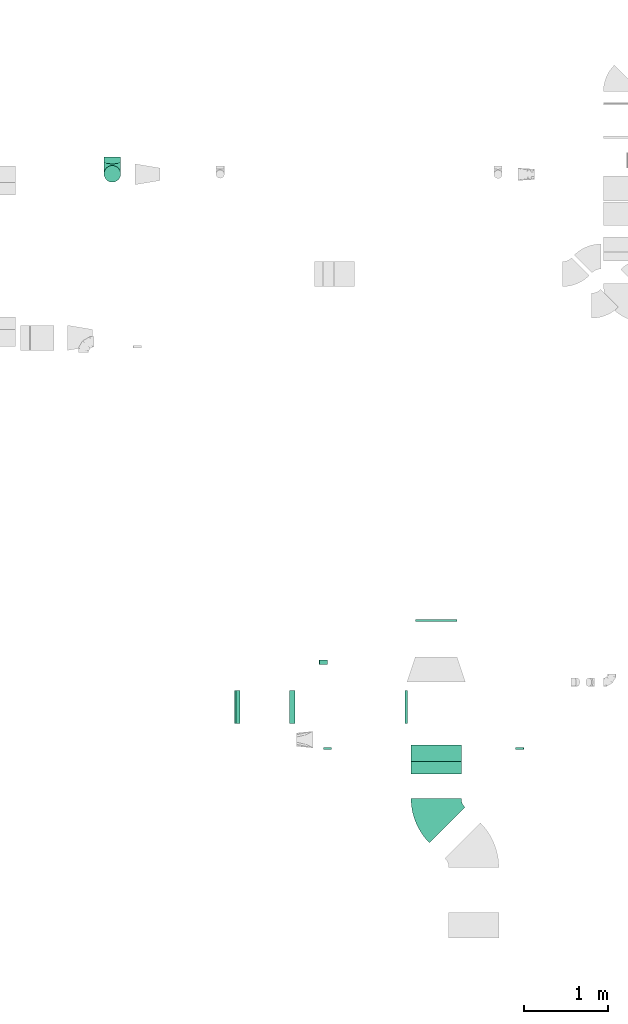
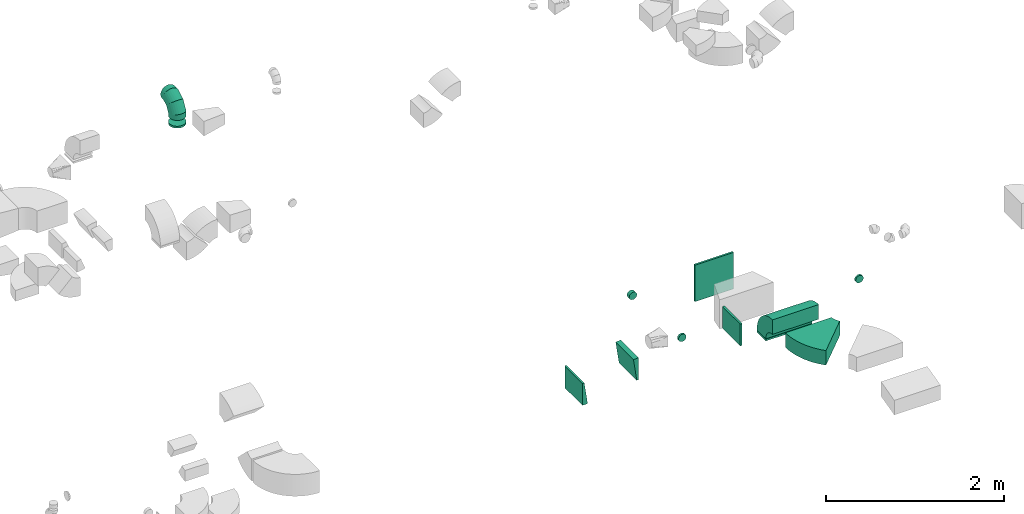
# One storey, part 21 of 44: 12 flow fittings.
"""IFC2X3 building model written with IfcOpenShell, lengths in millimetres."""

import ifcopenshell
import ifcopenshell.guid

model = None  # the IFC model being written
_history = None  # IfcOwnerHistory: only IFC2X3 demands one
_inside = {}  # id of a spatial element -> (the spatial element, [elements in it])
_under = {}  # id of a project, library or spatial element -> (it, [spatial elements below it])
_declared = {}  # id of a project -> (the project, [libraries it declares])
_typed = {}  # id of a type object -> (the type object, [elements of that type])
_made_of = {}  # id of a material, layer set ... -> (it, [elements and type objects made of it])


def new_model(schema):
    """Start an empty IFC model of exactly this schema.

    Asked for "IFC4X3", IfcOpenShell would pick the latest addendum, in which some entities
    have other attributes; the version numbers below select the first issue.
    IFC2X3 requires an IfcOwnerHistory on every rooted entity: one is made here for all.
    """
    global model, _history
    if schema == "IFC4X3":
        model = ifcopenshell.file(schema_version=(4, 3, 0, 0))
    else:
        model = ifcopenshell.file(schema=schema)
    _inside.clear()
    _under.clear()
    _declared.clear()
    _typed.clear()
    _made_of.clear()
    _history = None
    if model.schema == "IFC2X3":
        org = make("IfcOrganization", Name="unknown")
        user = make(
            "IfcPersonAndOrganization",
            ThePerson=make("IfcPerson", FamilyName="unknown"),
            TheOrganization=org,
        )
        app = make(
            "IfcApplication",
            ApplicationDeveloper=org,
            Version="unknown",
            ApplicationFullName="unknown",
            ApplicationIdentifier="unknown",
        )
        _history = make(
            "IfcOwnerHistory",
            OwningUser=user,
            OwningApplication=app,
            ChangeAction="ADDED",
            CreationDate=0,
        )
    return model


def make(cls, **values):
    """One entity of the class cls with the attributes given. An attribute that is None is left unset."""
    return model.create_entity(
        cls, **{name: value for name, value in values.items() if value is not None}
    )


def entity(cls, *values):
    """Any entity or typed value of the class cls, its attributes in the order of the schema. None: left unset."""
    e = model.create_entity(cls)
    for i, value in enumerate(values):
        if value is not None:
            e[i] = value
    return e


def rooted(cls, **values):
    """An entity with a GlobalId (a new one), such as an element, a storey or a relation."""
    return make(cls, GlobalId=ifcopenshell.guid.new(), OwnerHistory=_history, **values)


def si_unit(unit_type, name, prefix=None):
    """IfcSIUnit, for example si_unit("LENGTHUNIT", "METRE", prefix="MILLI")."""
    return make("IfcSIUnit", UnitType=unit_type, Prefix=prefix, Name=name)


def converted_unit(unit_type, name, factor, base, dimensions=None, offset=None):
    """IfcConversionBasedUnit, such as the inch: factor (a typed value) times the base unit."""
    return make(
        "IfcConversionBasedUnit"
        if offset is None
        else "IfcConversionBasedUnitWithOffset",
        ConversionOffset=offset,
        Dimensions=None
        if dimensions is None
        else entity("IfcDimensionalExponents", *dimensions),
        UnitType=unit_type,
        Name=name,
        ConversionFactor=make(
            "IfcMeasureWithUnit", ValueComponent=factor, UnitComponent=base
        ),
    )


def derived_unit(unit_type, elements):
    """IfcDerivedUnit: a product of units, each with its exponent."""
    return make(
        "IfcDerivedUnit",
        Elements=[
            make("IfcDerivedUnitElement", Unit=unit, Exponent=power)
            for unit, power in elements
        ],
        UnitType=unit_type,
    )


def assignment(units):
    """IfcUnitAssignment: the units of a project."""
    return None if units is None else make("IfcUnitAssignment", Units=units)


def point(xyz):
    """IfcCartesianPoint."""
    return None if xyz is None else make("IfcCartesianPoint", Coordinates=xyz)


def direction(xyz):
    """IfcDirection."""
    return None if xyz is None else make("IfcDirection", DirectionRatios=xyz)


def frame(location, z_axis=None, x_axis=None):
    """IfcAxis2Placement3D, a coordinate frame: its origin and axes. An axis left out is left unset."""
    return make(
        "IfcAxis2Placement3D",
        Location=point(location),
        Axis=direction(z_axis),
        RefDirection=direction(x_axis),
    )


def frame_2d(location, x_axis=None):
    """IfcAxis2Placement2D, a coordinate frame in the plane: its origin and x axis."""
    return make(
        "IfcAxis2Placement2D", Location=point(location), RefDirection=direction(x_axis)
    )


def origin():
    """The frame at (0, 0, 0) with its axes left unset."""
    return frame((0.0, 0.0, 0.0))


def origin_2d_with_axis():
    """The frame at (0, 0) in the plane with the x axis (1, 0) written out."""
    return frame_2d((0.0, 0.0), x_axis=(1.0, 0.0))


def place(relative_to, where):
    """IfcLocalPlacement: puts the frame where relative to a parent placement (None: the world)."""
    return make(
        "IfcLocalPlacement", PlacementRelTo=relative_to, RelativePlacement=where
    )


def context(
    kind, dimensions, precision=None, world=None, true_north=None, identifier=None
):
    """IfcGeometricRepresentationContext, for example the 3D "Model" context."""
    return make(
        "IfcGeometricRepresentationContext",
        ContextIdentifier=identifier,
        ContextType=kind,
        CoordinateSpaceDimension=dimensions,
        Precision=precision,
        WorldCoordinateSystem=world,
        TrueNorth=true_north,
    )


def subcontext(parent, identifier, kind, view, scale=None):
    """IfcGeometricRepresentationSubContext, for example "Body" below "Model"."""
    return make(
        "IfcGeometricRepresentationSubContext",
        ContextIdentifier=identifier,
        ContextType=kind,
        ParentContext=parent,
        TargetScale=scale,
        TargetView=view,
    )


def project(units=None, contexts=None):
    """IfcProject with its units and contexts."""
    return rooted(
        "IfcProject",
        Name="project",
        RepresentationContexts=contexts,
        UnitsInContext=assignment(units),
    )


def spatial(cls, under=None, at=None, **own):
    """A site, building, storey or space (cls), placed at a placement, below another one or the project."""
    s = rooted(cls, ObjectPlacement=at, **own)
    if under is not None:
        _under.setdefault(under.id(), (under, []))[1].append(s)
    return s


def polyline(points):
    """IfcPolyline through the points."""
    return make("IfcPolyline", Points=[point(p) for p in points])


def circle_curve(where, radius):
    """IfcCircle in the frame where."""
    return make("IfcCircle", Position=where, Radius=radius)


def parameter(value):
    """IfcParameterValue: where a trimmed curve begins or ends, as a parameter of its basis curve."""
    return model.create_entity("IfcParameterValue", value)


def trimmed(basis, trim1, trim2, sense, master):
    """IfcTrimmedCurve: the piece of a basis curve between two trims."""
    return make(
        "IfcTrimmedCurve",
        BasisCurve=basis,
        Trim1=trim1,
        Trim2=trim2,
        SenseAgreement=sense,
        MasterRepresentation=master,
    )


def segment(curve, same_sense, transition):
    """IfcCompositeCurveSegment."""
    return make(
        "IfcCompositeCurveSegment",
        Transition=transition,
        SameSense=same_sense,
        ParentCurve=curve,
    )


def composite_curve(segments, self_intersect=None):
    """IfcCompositeCurve: segments joined end to end."""
    return make("IfcCompositeCurve", Segments=segments, SelfIntersect=self_intersect)


def profile(cls, at=None, kind="AREA", **sizes):
    """A parametric profile (cls). Its sizes go by their IFC names, for example OverallWidth=200.0."""
    return make(cls, ProfileType=kind, Position=at, **sizes)


def rectangle(**sizes):
    """IfcRectangleProfileDef."""
    return profile("IfcRectangleProfileDef", **sizes)


def outline(outer, holes=None, kind="AREA"):
    """IfcArbitraryClosedProfileDef: a profile drawn as a closed curve; with holes, ...WithVoids."""
    if holes is None:
        return make("IfcArbitraryClosedProfileDef", ProfileType=kind, OuterCurve=outer)
    return make(
        "IfcArbitraryProfileDefWithVoids",
        ProfileType=kind,
        OuterCurve=outer,
        InnerCurves=holes,
    )


def extrude(swept, where, along, depth):
    """IfcExtrudedAreaSolid: the profile swept, set in the frame where, extruded along a direction by depth."""
    return make(
        "IfcExtrudedAreaSolid",
        SweptArea=swept,
        Position=where,
        ExtrudedDirection=direction(along),
        Depth=depth,
    )


def faces_of(points, faces, orient=None, outer=None):
    """IfcFace entities. A face is a list of loops; a loop is a list of indices into points, from 0.

    orient and outer hold one flag for each loop. By default every Orientation is true, the
    first loop of a face is its IfcFaceOuterBound and the others are IfcFaceBound.
    """
    made = []
    for i, loops in enumerate(faces):
        bounds = []
        for j, loop in enumerate(loops):
            is_outer = j == 0 if outer is None else outer[i][j]
            bounds.append(
                make(
                    "IfcFaceOuterBound" if is_outer else "IfcFaceBound",
                    Bound=make("IfcPolyLoop", Polygon=[points[k] for k in loop]),
                    Orientation=True if orient is None else orient[i][j],
                )
            )
        made.append(make("IfcFace", Bounds=bounds))
    return made


def faceted_brep(points, faces, orient=None, outer=None, voids=None):
    """IfcFacetedBrep: a solid bounded by flat faces; with voids (closed shells), ...WithVoids."""
    shared = [point(p) for p in points]
    hull = make("IfcClosedShell", CfsFaces=faces_of(shared, faces, orient, outer))
    if voids is None:
        return make("IfcFacetedBrep", Outer=hull)
    return make(
        "IfcFacetedBrepWithVoids",
        Outer=hull,
        Voids=[
            make(cls, CfsFaces=faces_of(shared, fs, o, b)) for cls, fs, o, b in voids
        ],
    )


def shape(context_of_items, identifier, shape_type, items):
    """IfcShapeRepresentation: the items that make up one representation, for example the "Body"."""
    return make(
        "IfcShapeRepresentation",
        ContextOfItems=context_of_items,
        RepresentationIdentifier=identifier,
        RepresentationType=shape_type,
        Items=items,
    )


def source(mapping_origin, context_of_items, identifier, shape_type, items):
    """IfcRepresentationMap: a shape defined once, which mapped items show again and again."""
    return make(
        "IfcRepresentationMap",
        MappingOrigin=mapping_origin,
        MappedRepresentation=shape(context_of_items, identifier, shape_type, items),
    )


def transform(
    local_origin,
    x_axis=None,
    y_axis=None,
    z_axis=None,
    scale=None,
    scale2=None,
    scale3=None,
    uniform=True,
):
    """IfcCartesianTransformationOperator3D, or its non-uniform kind. x_axis, y_axis, z_axis: its Axis1, 2, 3."""
    if uniform:
        return make(
            "IfcCartesianTransformationOperator3D",
            Axis1=direction(x_axis),
            Axis2=direction(y_axis),
            LocalOrigin=point(local_origin),
            Scale=scale,
            Axis3=direction(z_axis),
        )
    return make(
        "IfcCartesianTransformationOperator3DnonUniform",
        Axis1=direction(x_axis),
        Axis2=direction(y_axis),
        LocalOrigin=point(local_origin),
        Scale=scale,
        Axis3=direction(z_axis),
        Scale2=scale2,
        Scale3=scale3,
    )


def mapped(mapping_source, mapping_target):
    """IfcMappedItem: shows the shape of a source again, moved by a transform."""
    return make(
        "IfcMappedItem", MappingSource=mapping_source, MappingTarget=mapping_target
    )


def material(Name=None, Category=None):
    """IfcMaterial."""
    return make("IfcMaterial", Name=Name, Category=Category)


def made_of(thing, what):
    """Note that an element or type object is made of a material, layer set ...; save() writes the relation."""
    if what is not None:
        _made_of.setdefault(what.id(), (what, []))[1].append(thing)
    return thing


def type_object(cls, material=None, **own):
    """A type object (cls), such as IfcWallType, which elements share."""
    return made_of(rooted(cls, **own), material)


def type_shapes(of_type, sources):
    """Give a type object the sources (RepresentationMaps) that its elements show as mapped items."""
    of_type.RepresentationMaps = sources


def element(
    cls,
    number,
    at=None,
    inside=None,
    cuts=None,
    type_object=None,
    material=None,
    context=None,
    identifier="Body",
    shape_type=None,
    held_by="IfcProductDefinitionShape",
    body=None,
    shapes=None,
    **own,
):
    """One element of the class cls, such as IfcWall. Its Tag is "e" and its number.

    at: its placement. inside: the storey or other place that contains it. cuts: it is an
    opening in that element (IfcRelVoidsElement). A single representation is given by context,
    identifier, shape_type and body (its items); several are given by shapes. held_by: the class
    of the entity that holds the representations. save() writes the other relations.
    """
    e = rooted(cls, Tag="e%d" % number, ObjectPlacement=at, **own)
    if body is not None:
        shapes = [shape(context, identifier, shape_type, body)]
    if shapes is not None:
        e.Representation = make(held_by, Representations=shapes)
    if inside is not None:
        _inside.setdefault(inside.id(), (inside, []))[1].append(e)
    if cuts is not None:
        rooted(
            "IfcRelVoidsElement", RelatingBuildingElement=cuts, RelatedOpeningElement=e
        )
    if type_object is not None:
        _typed.setdefault(type_object.id(), (type_object, []))[1].append(e)
    return made_of(e, material)


def aggregate(whole, parts):
    """IfcRelAggregates: a whole, such as a stair, and the parts it consists of."""
    return rooted("IfcRelAggregates", RelatingObject=whole, RelatedObjects=parts)


def save(model, path):
    """Write the relations noted so far, then the file.

    IfcRelAggregates (storeys below a building ...), IfcRelContainedInSpatialStructure (elements
    in a storey), IfcRelDefinesByType, IfcRelAssociatesMaterial and IfcRelDeclares: one each for
    every whole, place, type object, material and project.
    """
    for whole, parts in _under.values():
        aggregate(whole, parts)
    for where, things in _inside.values():
        rooted(
            "IfcRelContainedInSpatialStructure",
            RelatedElements=things,
            RelatingStructure=where,
        )
    for kind, things in _typed.values():
        rooted("IfcRelDefinesByType", RelatedObjects=things, RelatingType=kind)
    for what, things in _made_of.values():
        rooted("IfcRelAssociatesMaterial", RelatedObjects=things, RelatingMaterial=what)
    for by, libraries in _declared.values():
        rooted("IfcRelDeclares", RelatingContext=by, RelatedDefinitions=libraries)
    model.write(path)


model = new_model("IFC2X3")

# Units and contexts
model_context = context("Model", 3, precision=0.01, world=origin(), true_north=direction((6.12303176911189e-17, 1.0)))
body_context = subcontext(model_context, "Body", "Model", "MODEL_VIEW")
ifc_project = project(units=[si_unit("LENGTHUNIT", "METRE", prefix="MILLI"), si_unit("AREAUNIT", "SQUARE_METRE"), si_unit("VOLUMEUNIT", "CUBIC_METRE"), converted_unit("PLANEANGLEUNIT", "DEGREE", entity("IfcRatioMeasure", 0.0174532925199433), si_unit("PLANEANGLEUNIT", "RADIAN"), dimensions=[0, 0, 0, 0, 0, 0, 0]), si_unit("MASSUNIT", "GRAM", prefix="KILO"), derived_unit("MASSDENSITYUNIT", [(si_unit("MASSUNIT", "GRAM", prefix="KILO"), 1), (si_unit("LENGTHUNIT", "METRE"), -3)]), derived_unit("MOMENTOFINERTIAUNIT", [(si_unit("LENGTHUNIT", "METRE"), 4)]), si_unit("TIMEUNIT", "SECOND"), si_unit("FREQUENCYUNIT", "HERTZ"), si_unit("THERMODYNAMICTEMPERATUREUNIT", "DEGREE_CELSIUS"), derived_unit("THERMALTRANSMITTANCEUNIT", [(si_unit("MASSUNIT", "GRAM", prefix="KILO"), 1), (si_unit("THERMODYNAMICTEMPERATUREUNIT", "KELVIN"), -1), (si_unit("TIMEUNIT", "SECOND"), -3)]), derived_unit("VOLUMETRICFLOWRATEUNIT", [(si_unit("LENGTHUNIT", "METRE"), 3), (si_unit("TIMEUNIT", "SECOND"), -1)]), derived_unit("MASSFLOWRATEUNIT", [(si_unit("MASSUNIT", "GRAM", prefix="KILO"), 1), (si_unit("TIMEUNIT", "SECOND"), -1)]), derived_unit("ROTATIONALFREQUENCYUNIT", [(si_unit("TIMEUNIT", "SECOND"), -1)]), si_unit("ELECTRICCURRENTUNIT", "AMPERE"), si_unit("ELECTRICVOLTAGEUNIT", "VOLT"), si_unit("POWERUNIT", "WATT"), si_unit("FORCEUNIT", "NEWTON", prefix="KILO"), si_unit("ILLUMINANCEUNIT", "LUX"), si_unit("LUMINOUSFLUXUNIT", "LUMEN"), si_unit("LUMINOUSINTENSITYUNIT", "CANDELA"), derived_unit("USERDEFINED", [(si_unit("MASSUNIT", "GRAM", prefix="KILO"), -1), (si_unit("LENGTHUNIT", "METRE"), -2), (si_unit("TIMEUNIT", "SECOND"), 3), (si_unit("LUMINOUSFLUXUNIT", "LUMEN"), 1)]), derived_unit("LINEARVELOCITYUNIT", [(si_unit("LENGTHUNIT", "METRE"), 1), (si_unit("TIMEUNIT", "SECOND"), -1)]), si_unit("PRESSUREUNIT", "PASCAL"), derived_unit("USERDEFINED", [(si_unit("LENGTHUNIT", "METRE"), -2), (si_unit("MASSUNIT", "GRAM", prefix="KILO"), 1), (si_unit("TIMEUNIT", "SECOND"), -2)]), derived_unit("LINEARFORCEUNIT", [(si_unit("MASSUNIT", "GRAM", prefix="KILO"), 1), (si_unit("LENGTHUNIT", "METRE"), 1), (si_unit("TIMEUNIT", "SECOND"), -2), (si_unit("LENGTHUNIT", "METRE"), -1)]), derived_unit("PLANARFORCEUNIT", [(si_unit("MASSUNIT", "GRAM", prefix="KILO"), 1), (si_unit("LENGTHUNIT", "METRE"), 1), (si_unit("TIMEUNIT", "SECOND"), -2), (si_unit("LENGTHUNIT", "METRE"), -2)])], contexts=[model_context])

# Site, building, storey
site_placement = place(None, origin())
site = spatial("IfcSite", under=ifc_project, at=site_placement, CompositionType="ELEMENT")
building_placement = place(site_placement, origin())
building = spatial("IfcBuilding", under=site, at=building_placement, CompositionType="ELEMENT")
storey_placement = place(building_placement, frame((0.0, 0.0, 15900.0)))
storey = spatial("IfcBuildingStorey", under=building, at=storey_placement, CompositionType="ELEMENT", Elevation=15900.0)

# Flow fittings
ifc_material = material()
duct_fitting_type_1 = type_object("IfcDuctFittingType", PredefinedType="NOTDEFINED", material=ifc_material)
shared_shape_1 = source(origin(), body_context, "Body", "SweptSolid", [
    extrude(rectangle(XDim=26.0960000000051, YDim=500.0, at=origin_2d_with_axis()), frame((6.95, 0.0, -250.0)), (0.0, 0.0, 1.0), 500.0),
])
type_shapes(duct_fitting_type_1, [shared_shape_1])
flow_fitting_1_placement = place(storey_placement, frame((44620.22, 10801.83, 2825.0), z_axis=(-1.0, 0.0, 0.0), x_axis=(0.0, -1.0, 0.0)))
element("IfcFlowFitting", 1, at=flow_fitting_1_placement, inside=storey, type_object=duct_fitting_type_1, material=ifc_material, context=body_context, shape_type="MappedRepresentation", body=[
    mapped(shared_shape_1, transform((0.0, 0.0, 0.0), scale=1.0)),
])
duct_fitting_type_2 = type_object("IfcDuctFittingType", PredefinedType="NOTDEFINED", material=ifc_material)
shared_shape_2 = source(origin(), body_context, "Body", "SweptSolid", [
    extrude(rectangle(XDim=26.0960000000006, YDim=400.0, at=origin_2d_with_axis()), frame((6.95, 0.0, -150.0)), (0.0, 0.0, 1.0), 300.0),
])
type_shapes(duct_fitting_type_2, [shared_shape_2])
flow_fitting_2_placement = place(storey_placement, frame((44270.22, 9760.56, 2900.0), z_axis=(0.0, 0.0, -1.0), x_axis=(-1.0, 0.0, 0.0)))
element("IfcFlowFitting", 2, at=flow_fitting_2_placement, inside=storey, type_object=duct_fitting_type_2, material=ifc_material, context=body_context, shape_type="MappedRepresentation", body=[
    mapped(shared_shape_2, transform((0.0, 0.0, 0.0), scale=1.0)),
])
duct_fitting_type_3 = type_object("IfcDuctFittingType", PredefinedType="NOTDEFINED", material=ifc_material)
shared_shape_3 = source(origin(), body_context, "Body", "SweptSolid", [
    extrude(rectangle(XDim=600.0, YDim=26.096000000052, at=origin_2d_with_axis()), frame((6.95, 0.0, -100.0), z_axis=(0.0, 0.0, 1.0), x_axis=(0.0, -1.0, 0.0)), (0.0, 0.0, 1.0), 200.0),
])
type_shapes(duct_fitting_type_3, [shared_shape_3])
flow_fitting_3_placement = place(storey_placement, frame((44620.22, 9206.34, 3075.0), z_axis=(0.0, -1.0, 0.0), x_axis=(0.0, 0.0, 1.0)))
element("IfcFlowFitting", 3, at=flow_fitting_3_placement, inside=storey, type_object=duct_fitting_type_3, material=ifc_material, context=body_context, shape_type="MappedRepresentation", body=[
    mapped(shared_shape_3, transform((0.0, 0.0, 0.0), scale=1.0)),
])
duct_fitting_type_4 = type_object("IfcDuctFittingType", PredefinedType="NOTDEFINED", material=ifc_material)
shared_shape_4 = source(origin(), body_context, "Body", "Brep", [
    faceted_brep([(-200.0, 0.0, -100.0), (-200.0, -25.88, -96.59), (-200.0, -50.0, -86.6), (-200.0, -70.71, -70.71), (-200.0, -86.6, -50.0), (-200.0, -96.59, -25.88), (-200.0, -100.0, 0.0), (-200.0, -96.59, 25.88), (-200.0, -86.6, 50.0), (-200.0, -70.71, 70.71), (-200.0, -50.0, 86.6), (-200.0, -25.88, 96.59), (-200.0, 0.0, 100.0), (-200.0, 25.88, 96.59), (-200.0, 50.0, 86.6), (-200.0, 70.71, 70.71), (-200.0, 86.6, 50.0), (-200.0, 96.59, 25.88), (-200.0, 100.0, 0.0), (-200.0, 96.59, -25.88), (-200.0, 86.6, -50.0), (-200.0, 70.71, -70.71), (-200.0, 50.0, -86.6), (-200.0, 25.88, -96.59), (-153.35, 25.88, 96.59), (-159.81, 50.0, 86.6), (-146.41, 0.0, 100.0), (-165.36, 70.71, 70.71), (-172.29, 96.59, 25.88), (-173.21, 100.0, 0.0), (-169.62, 86.6, 50.0), (-169.62, 86.6, -50.0), (-165.36, 70.71, -70.71), (-172.29, 96.59, -25.88), (-153.35, 25.88, -96.59), (-146.41, 0.0, -100.0), (-159.81, 50.0, -86.6), (-139.48, -25.88, -96.59), (-133.01, -50.0, -86.6), (-127.46, -70.71, -70.71), (-123.21, -86.6, -50.0), (-120.53, -96.59, -25.88), (-119.62, -100.0, 0.0), (-120.53, -96.59, 25.88), (-123.21, -86.6, 50.0), (-127.46, -70.71, 70.71), (-133.01, -50.0, 86.6), (-139.48, -25.88, 96.59), (-72.54, 72.54, 96.59), (-90.19, 90.19, 86.6), (-53.59, 53.59, 100.0), (-105.35, 105.35, 70.71), (-116.99, 116.99, 50.0), (-124.3, 124.3, 25.88), (-126.79, 126.79, 0.0), (-124.3, 124.3, -25.88), (-116.99, 116.99, -50.0), (-105.35, 105.35, -70.71), (-72.54, 72.54, -96.59), (-53.59, 53.59, -100.0), (-90.19, 90.19, -86.6), (-34.64, 34.64, -96.59), (-16.99, 16.99, -86.6), (-1.83, 1.83, -70.71), (9.81, -9.81, -50.0), (17.12, -17.12, -25.88), (19.62, -19.62, 0.0), (17.12, -17.12, 25.88), (9.81, -9.81, 50.0), (-1.83, 1.83, 70.71), (-16.99, 16.99, 86.6), (-34.64, 34.64, 96.59), (-25.88, 153.35, 96.59), (-50.0, 159.81, 86.6), (0.0, 146.41, 100.0), (-70.71, 165.36, 70.71), (-86.6, 169.62, 50.0), (-96.59, 172.29, 25.88), (-100.0, 173.21, 0.0), (-96.59, 172.29, -25.88), (-86.6, 169.62, -50.0), (-70.71, 165.36, -70.71), (-25.88, 153.35, -96.59), (0.0, 146.41, -100.0), (-50.0, 159.81, -86.6), (25.88, 139.48, -96.59), (50.0, 133.01, -86.6), (70.71, 127.46, -70.71), (86.6, 123.21, -50.0), (96.59, 120.53, -25.88), (100.0, 119.62, 0.0), (96.59, 120.53, 25.88), (86.6, 123.21, 50.0), (70.71, 127.46, 70.71), (50.0, 133.01, 86.6), (25.88, 139.48, 96.59), (-25.88, 200.0, -96.59), (-50.0, 200.0, -86.6), (-70.71, 200.0, -70.71), (-86.6, 200.0, -50.0), (-96.59, 200.0, -25.88), (-100.0, 200.0, 0.0), (-96.59, 200.0, 25.88), (-86.6, 200.0, 50.0), (-70.71, 200.0, 70.71), (-50.0, 200.0, 86.6), (-25.88, 200.0, 96.59), (0.0, 200.0, 100.0), (25.88, 200.0, 96.59), (50.0, 200.0, 86.6), (70.71, 200.0, 70.71), (86.6, 200.0, 50.0), (96.59, 200.0, 25.88), (100.0, 200.0, 0.0), (96.59, 200.0, -25.88), (86.6, 200.0, -50.0), (70.71, 200.0, -70.71), (50.0, 200.0, -86.6), (25.88, 200.0, -96.59), (0.0, 200.0, -100.0)], [[[0, 1, 2, 3, 4, 5, 6, 7, 8, 9, 10, 11, 12, 13, 14, 15, 16, 17, 18, 19, 20, 21, 22, 23]], [[24, 25, 14, 13]], [[26, 24, 13, 12]], [[14, 25, 27, 15]], [[28, 29, 18, 17]], [[30, 28, 17, 16]], [[15, 27, 30, 16]], [[20, 31, 32, 21]], [[33, 31, 20, 19]], [[18, 29, 33, 19]], [[34, 35, 0, 23]], [[36, 34, 23, 22]], [[32, 36, 22, 21]], [[1, 0, 35, 37]], [[2, 1, 37, 38]], [[38, 39, 3, 2]], [[5, 4, 40, 41]], [[6, 5, 41, 42]], [[39, 40, 4, 3]], [[6, 42, 43, 7]], [[7, 43, 44, 8]], [[8, 44, 45, 9]], [[9, 45, 46, 10]], [[10, 46, 47, 11]], [[26, 12, 11, 47]], [[48, 49, 25, 24]], [[50, 48, 24, 26]], [[27, 25, 49, 51]], [[52, 53, 28, 30]], [[51, 52, 30, 27]], [[29, 28, 53, 54]], [[55, 56, 31, 33]], [[54, 55, 33, 29]], [[32, 31, 56, 57]], [[58, 59, 35, 34]], [[60, 58, 34, 36]], [[57, 60, 36, 32]], [[37, 35, 59, 61]], [[38, 37, 61, 62]], [[39, 38, 62, 63]], [[41, 40, 64, 65]], [[42, 41, 65, 66]], [[63, 64, 40, 39]], [[43, 42, 66, 67]], [[44, 43, 67, 68]], [[68, 69, 45, 44]], [[46, 45, 69, 70]], [[47, 46, 70, 71]], [[26, 47, 71, 50]], [[72, 73, 49, 48]], [[74, 72, 48, 50]], [[51, 49, 73, 75]], [[76, 77, 53, 52]], [[75, 76, 52, 51]], [[54, 53, 77, 78]], [[79, 80, 56, 55]], [[78, 79, 55, 54]], [[57, 56, 80, 81]], [[82, 83, 59, 58]], [[84, 82, 58, 60]], [[81, 84, 60, 57]], [[61, 59, 83, 85]], [[62, 61, 85, 86]], [[63, 62, 86, 87]], [[65, 64, 88, 89]], [[66, 65, 89, 90]], [[87, 88, 64, 63]], [[67, 66, 90, 91]], [[68, 67, 91, 92]], [[92, 93, 69, 68]], [[70, 69, 93, 94]], [[71, 70, 94, 95]], [[50, 71, 95, 74]], [[96, 97, 98, 99, 100, 101, 102, 103, 104, 105, 106, 107, 108, 109, 110, 111, 112, 113, 114, 115, 116, 117, 118, 119]], [[72, 74, 107, 106]], [[73, 72, 106, 105]], [[75, 73, 105, 104]], [[102, 101, 78, 77]], [[103, 102, 77, 76]], [[75, 104, 103, 76]], [[78, 101, 100, 79]], [[79, 100, 99, 80]], [[80, 99, 98, 81]], [[84, 97, 96, 82]], [[82, 96, 119, 83]], [[84, 81, 98, 97]], [[118, 117, 86, 85]], [[119, 118, 85, 83]], [[116, 87, 86, 117]], [[88, 115, 114, 89]], [[89, 114, 113, 90]], [[115, 88, 87, 116]], [[91, 90, 113, 112]], [[92, 91, 112, 111]], [[111, 110, 93, 92]], [[95, 94, 109, 108]], [[74, 95, 108, 107]], [[110, 109, 94, 93]]]),
])
type_shapes(duct_fitting_type_4, [shared_shape_4])
flow_fitting_4_placement = place(storey_placement, frame((40747.28, 16136.51, 3350.0), z_axis=(1.0, 0.0, 0.0), x_axis=(0.0, -1.0, 0.0)))
element("IfcFlowFitting", 4, at=flow_fitting_4_placement, inside=storey, type_object=duct_fitting_type_4, material=ifc_material, context=body_context, shape_type="MappedRepresentation", body=[
    mapped(shared_shape_4, transform((0.0, 0.0, 0.0), scale=1.0)),
])
duct_fitting_type_5 = type_object("IfcDuctFittingType", PredefinedType="NOTDEFINED", material=ifc_material)
shared_shape_5 = source(origin(), body_context, "Body", "Brep", [
    faceted_brep([(20.0, 25.88, -96.59), (20.0, 50.0, -86.6), (20.0, 70.71, -70.71), (20.0, 86.6, -50.0), (20.0, 96.59, -25.88), (20.0, 100.0, 0.0), (20.0, 96.59, 25.88), (20.0, 86.6, 50.0), (20.0, 70.71, 70.71), (20.0, 50.0, 86.6), (20.0, 25.88, 96.59), (20.0, 0.0, 100.0), (20.0, -25.88, 96.59), (20.0, -50.0, 86.6), (20.0, -70.71, 70.71), (20.0, -86.6, 50.0), (20.0, -96.59, 25.88), (20.0, -100.0, 0.0), (20.0, -96.59, -25.88), (20.0, -86.6, -50.0), (20.0, -70.71, -70.71), (20.0, -50.0, -86.6), (20.0, -25.88, -96.59), (20.0, 0.0, -100.0), (0.0, 0.0, 100.0), (0.0, 25.88, 96.59), (-6.1, 25.88, 96.59), (-6.1, 0.0, 100.0), (0.0, 50.0, 86.6), (-6.1, 50.0, 86.6), (0.0, 70.71, 70.71), (-6.1, 70.71, 70.71), (0.0, 86.6, 50.0), (0.0, 96.59, 25.88), (-6.1, 96.59, 25.88), (-6.1, 86.6, 50.0), (0.0, 100.0, 0.0), (-6.1, 100.0, 0.0), (0.0, 96.59, -25.88), (-6.1, 96.59, -25.88), (0.0, 86.6, -50.0), (-6.1, 86.6, -50.0), (0.0, 70.71, -70.71), (-6.1, 70.71, -70.71), (0.0, 50.0, -86.6), (0.0, 25.88, -96.59), (-6.1, 25.88, -96.59), (-6.1, 50.0, -86.6), (0.0, 0.0, -100.0), (-6.1, 0.0, -100.0), (0.0, -25.88, -96.59), (-6.1, -25.88, -96.59), (0.0, -50.0, -86.6), (-6.1, -50.0, -86.6), (0.0, -70.71, -70.71), (-6.1, -70.71, -70.71), (0.0, -86.6, -50.0), (0.0, -96.59, -25.88), (-6.1, -96.59, -25.88), (-6.1, -86.6, -50.0), (0.0, -100.0, 0.0), (-6.1, -100.0, 0.0), (0.0, -96.59, 25.88), (-6.1, -96.59, 25.88), (0.0, -86.6, 50.0), (-6.1, -86.6, 50.0), (0.0, -70.71, 70.71), (-6.1, -70.71, 70.71), (0.0, -50.0, 86.6), (0.0, -25.88, 96.59), (-6.1, -25.88, 96.59), (-6.1, -50.0, 86.6)], [[[0, 1, 2, 3, 4, 5, 6, 7, 8, 9, 10, 11, 12, 13, 14, 15, 16, 17, 18, 19, 20, 21, 22, 23]], [[24, 11, 10, 25, 26, 27]], [[25, 10, 9, 28, 29, 26]], [[28, 9, 8, 30, 31, 29]], [[32, 7, 6, 33, 34, 35]], [[33, 6, 5, 36, 37, 34]], [[30, 8, 7, 32, 35, 31]], [[36, 5, 4, 38, 39, 37]], [[38, 4, 3, 40, 41, 39]], [[40, 3, 2, 42, 43, 41]], [[44, 1, 0, 45, 46, 47]], [[45, 0, 23, 48, 49, 46]], [[42, 2, 1, 44, 47, 43]], [[48, 23, 22, 50, 51, 49]], [[50, 22, 21, 52, 53, 51]], [[52, 21, 20, 54, 55, 53]], [[56, 19, 18, 57, 58, 59]], [[57, 18, 17, 60, 61, 58]], [[54, 20, 19, 56, 59, 55]], [[60, 17, 16, 62, 63, 61]], [[62, 16, 15, 64, 65, 63]], [[64, 15, 14, 66, 67, 65]], [[68, 13, 12, 69, 70, 71]], [[69, 12, 11, 24, 27, 70]], [[66, 14, 13, 68, 71, 67]], [[49, 51, 53, 55, 59, 58, 61, 63, 65, 67, 71, 70, 27, 26, 29, 31, 35, 34, 37, 39, 41, 43, 47, 46]]]),
])
type_shapes(duct_fitting_type_5, [shared_shape_5])
flow_fitting_5_placement = place(storey_placement, frame((40747.28, 16136.51, 3050.0), z_axis=(0.0, 1.0, 0.0), x_axis=(0.0, 0.0, 1.0)))
element("IfcFlowFitting", 5, at=flow_fitting_5_placement, inside=storey, type_object=duct_fitting_type_5, material=ifc_material, context=body_context, shape_type="MappedRepresentation", body=[
    mapped(shared_shape_5, transform((0.0, 0.0, 0.0), scale=1.0)),
])
duct_fitting_type_6 = type_object("IfcDuctFittingType", PredefinedType="NOTDEFINED", material=ifc_material)
shared_shape_6 = source(origin(), body_context, "Body", "Brep", [
    faceted_brep([(20.0, 12.94, -48.3), (20.0, 25.0, -43.3), (20.0, 35.36, -35.36), (20.0, 43.3, -25.0), (20.0, 48.3, -12.94), (20.0, 50.0, 0.0), (20.0, 48.3, 12.94), (20.0, 43.3, 25.0), (20.0, 35.36, 35.36), (20.0, 25.0, 43.3), (20.0, 12.94, 48.3), (20.0, 0.0, 50.0), (20.0, -12.94, 48.3), (20.0, -25.0, 43.3), (20.0, -35.36, 35.36), (20.0, -43.3, 25.0), (20.0, -48.3, 12.94), (20.0, -50.0, 0.0), (20.0, -48.3, -12.94), (20.0, -43.3, -25.0), (20.0, -35.36, -35.36), (20.0, -25.0, -43.3), (20.0, -12.94, -48.3), (20.0, 0.0, -50.0), (0.0, 0.0, 50.0), (0.0, 12.94, 48.3), (-31.1, 12.94, 48.3), (-31.1, 0.0, 50.0), (0.0, 25.0, 43.3), (-31.1, 25.0, 43.3), (0.0, 35.36, 35.36), (-31.1, 35.36, 35.36), (0.0, 43.3, 25.0), (0.0, 48.3, 12.94), (-31.1, 48.3, 12.94), (-31.1, 43.3, 25.0), (0.0, 50.0, 0.0), (-31.1, 50.0, 0.0), (0.0, 48.3, -12.94), (-31.1, 48.3, -12.94), (0.0, 43.3, -25.0), (-31.1, 43.3, -25.0), (0.0, 35.36, -35.36), (-31.1, 35.36, -35.36), (0.0, 25.0, -43.3), (0.0, 12.94, -48.3), (-31.1, 12.94, -48.3), (-31.1, 25.0, -43.3), (0.0, 0.0, -50.0), (-31.1, 0.0, -50.0), (0.0, -12.94, -48.3), (-31.1, -12.94, -48.3), (0.0, -25.0, -43.3), (-31.1, -25.0, -43.3), (0.0, -35.36, -35.36), (-31.1, -35.36, -35.36), (0.0, -43.3, -25.0), (0.0, -48.3, -12.94), (-31.1, -48.3, -12.94), (-31.1, -43.3, -25.0), (0.0, -50.0, 0.0), (-31.1, -50.0, 0.0), (0.0, -48.3, 12.94), (-31.1, -48.3, 12.94), (0.0, -43.3, 25.0), (-31.1, -43.3, 25.0), (0.0, -35.36, 35.36), (-31.1, -35.36, 35.36), (0.0, -25.0, 43.3), (0.0, -12.94, 48.3), (-31.1, -12.94, 48.3), (-31.1, -25.0, 43.3)], [[[0, 1, 2, 3, 4, 5, 6, 7, 8, 9, 10, 11, 12, 13, 14, 15, 16, 17, 18, 19, 20, 21, 22, 23]], [[24, 11, 10, 25, 26, 27]], [[25, 10, 9, 28, 29, 26]], [[28, 9, 8, 30, 31, 29]], [[32, 7, 6, 33, 34, 35]], [[33, 6, 5, 36, 37, 34]], [[30, 8, 7, 32, 35, 31]], [[36, 5, 4, 38, 39, 37]], [[38, 4, 3, 40, 41, 39]], [[40, 3, 2, 42, 43, 41]], [[44, 1, 0, 45, 46, 47]], [[45, 0, 23, 48, 49, 46]], [[42, 2, 1, 44, 47, 43]], [[48, 23, 22, 50, 51, 49]], [[50, 22, 21, 52, 53, 51]], [[52, 21, 20, 54, 55, 53]], [[56, 19, 18, 57, 58, 59]], [[57, 18, 17, 60, 61, 58]], [[54, 20, 19, 56, 59, 55]], [[60, 17, 16, 62, 63, 61]], [[62, 16, 15, 64, 65, 63]], [[64, 15, 14, 66, 67, 65]], [[68, 13, 12, 69, 70, 71]], [[69, 12, 11, 24, 27, 70]], [[66, 14, 13, 68, 71, 67]], [[49, 51, 53, 55, 59, 58, 61, 63, 65, 67, 71, 70, 27, 26, 29, 31, 35, 34, 37, 39, 41, 43, 47, 46]]]),
])
type_shapes(duct_fitting_type_6, [shared_shape_6])
flow_fitting_6_placement = place(storey_placement, frame((43270.32, 10299.9, 3350.0), z_axis=(0.0, 0.0, -1.0), x_axis=(0.0, 1.0, 0.0)))
element("IfcFlowFitting", 6, at=flow_fitting_6_placement, inside=storey, type_object=duct_fitting_type_6, material=ifc_material, context=body_context, shape_type="MappedRepresentation", body=[
    mapped(shared_shape_6, transform((0.0, 0.0, 0.0), scale=1.0)),
])
duct_fitting_type_7 = type_object("IfcDuctFittingType", PredefinedType="NOTDEFINED", material=ifc_material)
shared_shape_7 = source(origin(), body_context, "Body", "Brep", [
    faceted_brep([(20.0, 12.94, -48.3), (20.0, 25.0, -43.3), (20.0, 35.36, -35.36), (20.0, 43.3, -25.0), (20.0, 48.3, -12.94), (20.0, 50.0, 0.0), (20.0, 48.3, 12.94), (20.0, 43.3, 25.0), (20.0, 35.36, 35.36), (20.0, 25.0, 43.3), (20.0, 12.94, 48.3), (20.0, 0.0, 50.0), (20.0, -12.94, 48.3), (20.0, -25.0, 43.3), (20.0, -35.36, 35.36), (20.0, -43.3, 25.0), (20.0, -48.3, 12.94), (20.0, -50.0, 0.0), (20.0, -48.3, -12.94), (20.0, -43.3, -25.0), (20.0, -35.36, -35.36), (20.0, -25.0, -43.3), (20.0, -12.94, -48.3), (20.0, 0.0, -50.0), (0.0, 0.0, 50.0), (0.0, 12.94, 48.3), (-6.1, 12.94, 48.3), (-6.1, 0.0, 50.0), (0.0, 25.0, 43.3), (-6.1, 25.0, 43.3), (0.0, 35.36, 35.36), (-6.1, 35.36, 35.36), (0.0, 43.3, 25.0), (0.0, 48.3, 12.94), (-6.1, 48.3, 12.94), (-6.1, 43.3, 25.0), (0.0, 50.0, 0.0), (-6.1, 50.0, 0.0), (0.0, 48.3, -12.94), (-6.1, 48.3, -12.94), (0.0, 43.3, -25.0), (-6.1, 43.3, -25.0), (0.0, 35.36, -35.36), (-6.1, 35.36, -35.36), (0.0, 25.0, -43.3), (0.0, 12.94, -48.3), (-6.1, 12.94, -48.3), (-6.1, 25.0, -43.3), (0.0, 0.0, -50.0), (-6.1, 0.0, -50.0), (0.0, -12.94, -48.3), (-6.1, -12.94, -48.3), (0.0, -25.0, -43.3), (-6.1, -25.0, -43.3), (0.0, -35.36, -35.36), (-6.1, -35.36, -35.36), (0.0, -43.3, -25.0), (0.0, -48.3, -12.94), (-6.1, -48.3, -12.94), (-6.1, -43.3, -25.0), (0.0, -50.0, 0.0), (-6.1, -50.0, 0.0), (0.0, -48.3, 12.94), (-6.1, -48.3, 12.94), (0.0, -43.3, 25.0), (-6.1, -43.3, 25.0), (0.0, -35.36, 35.36), (-6.1, -35.36, 35.36), (0.0, -25.0, 43.3), (0.0, -12.94, 48.3), (-6.1, -12.94, 48.3), (-6.1, -25.0, 43.3)], [[[0, 1, 2, 3, 4, 5, 6, 7, 8, 9, 10, 11, 12, 13, 14, 15, 16, 17, 18, 19, 20, 21, 22, 23]], [[24, 11, 10, 25, 26, 27]], [[25, 10, 9, 28, 29, 26]], [[28, 9, 8, 30, 31, 29]], [[32, 7, 6, 33, 34, 35]], [[33, 6, 5, 36, 37, 34]], [[30, 8, 7, 32, 35, 31]], [[36, 5, 4, 38, 39, 37]], [[38, 4, 3, 40, 41, 39]], [[40, 3, 2, 42, 43, 41]], [[44, 1, 0, 45, 46, 47]], [[45, 0, 23, 48, 49, 46]], [[42, 2, 1, 44, 47, 43]], [[48, 23, 22, 50, 51, 49]], [[50, 22, 21, 52, 53, 51]], [[52, 21, 20, 54, 55, 53]], [[56, 19, 18, 57, 58, 59]], [[57, 18, 17, 60, 61, 58]], [[54, 20, 19, 56, 59, 55]], [[60, 17, 16, 62, 63, 61]], [[62, 16, 15, 64, 65, 63]], [[64, 15, 14, 66, 67, 65]], [[68, 13, 12, 69, 70, 71]], [[69, 12, 11, 24, 27, 70]], [[66, 14, 13, 68, 71, 67]], [[49, 51, 53, 55, 59, 58, 61, 63, 65, 67, 71, 70, 27, 26, 29, 31, 35, 34, 37, 39, 41, 43, 47, 46]]]),
])
type_shapes(duct_fitting_type_7, [shared_shape_7])
for number, where, z_axis, x_axis in (
    (7, (43321.16, 9270.12, 3375.0), (0.0, 0.0, -1.0), (0.0, -1.0, 0.0)),
    (8, (45619.24, 9270.12, 3375.0), (0.0, 0.0, -1.0), (0.0, -1.0, 0.0)),
):
    element("IfcFlowFitting", number, at=place(storey_placement, frame(where, z_axis=z_axis, x_axis=x_axis)), inside=storey, type_object=duct_fitting_type_7, material=ifc_material, context=body_context, shape_type="MappedRepresentation", body=[
        mapped(shared_shape_7, transform((0.0, 0.0, 0.0), scale=1.0)),
    ])
duct_fitting_type_8 = type_object("IfcDuctFittingType", PredefinedType="NOTDEFINED", material=ifc_material)
shared_shape_8 = source(origin(), body_context, "Body", "SweptSolid", [
    extrude(outline(composite_curve([segment(polyline([(-365.9, -159.1), (234.1, -159.1)]), True, "CONTINUOUS"), segment(trimmed(circle_curve(frame_2d((384.1, -159.1), x_axis=(-0.707106781186553, 0.707106781186546)), 150.0), [parameter(0.0)], [parameter(45.0)], True, "PARAMETER"), False, "CONTINUOUS"), segment(polyline([(278.03, -53.03), (-146.23, 371.23)]), True, "CONTINUOUS"), segment(trimmed(circle_curve(frame_2d((384.1, -159.1), x_axis=(-0.707106781186553, 0.707106781186546)), 750.0), [parameter(0.0)], [parameter(45.0)], True, "PARAMETER"), True, "CONTINUOUS")], self_intersect=False)), frame((-27.3, 65.9, -100.0), z_axis=(0.0, 0.0, 1.0), x_axis=(-0.707106781186547, 0.707106781186548, 0.0)), (0.0, 0.0, 1.0), 200.0),
])
type_shapes(duct_fitting_type_8, [shared_shape_8])
flow_fitting_7_placement = place(storey_placement, frame((44620.22, 8479.34, 3350.0), z_axis=(0.0, 0.0, 1.0), x_axis=(0.0, -1.0, 0.0)))
element("IfcFlowFitting", 9, at=flow_fitting_7_placement, inside=storey, type_object=duct_fitting_type_8, material=ifc_material, context=body_context, shape_type="MappedRepresentation", body=[
    mapped(shared_shape_8, transform((0.0, 0.0, 0.0), scale=1.0)),
])
duct_fitting_type_9 = type_object("IfcDuctFittingType", PredefinedType="NOTDEFINED", material=ifc_material)
shared_shape_9 = source(origin(), body_context, "Body", "SweptSolid", [
    extrude(outline(composite_curve([segment(polyline([(-225.0, -125.0), (-25.0, -125.0)]), True, "CONTINUOUS"), segment(trimmed(circle_curve(frame_2d((125.0, -125.0), x_axis=(0.0, 1.0)), 150.0), [parameter(0.0)], [parameter(90.0000000000001)], True, "PARAMETER"), False, "CONTINUOUS"), segment(polyline([(125.0, 25.0), (125.0, 225.0)]), True, "CONTINUOUS"), segment(trimmed(circle_curve(frame_2d((125.0, -125.0), x_axis=(0.0, 1.0)), 350.0), [parameter(0.0)], [parameter(90.0000000000001)], True, "PARAMETER"), True, "CONTINUOUS")], self_intersect=False)), frame((-125.0, 125.0, -300.0), z_axis=(0.0, 0.0, 1.0), x_axis=(-1.0, 0.0, 0.0)), (0.0, 0.0, 1.0), 600.0),
])
type_shapes(duct_fitting_type_9, [shared_shape_9])
flow_fitting_8_placement = place(storey_placement, frame((44620.22, 9206.34, 3350.0), z_axis=(-1.0, 0.0, 0.0), x_axis=(0.0, 1.0, 0.0)))
element("IfcFlowFitting", 10, at=flow_fitting_8_placement, inside=storey, type_object=duct_fitting_type_9, material=ifc_material, context=body_context, shape_type="MappedRepresentation", body=[
    mapped(shared_shape_9, transform((0.0, 0.0, 0.0), scale=1.0)),
])
duct_fitting_type_10 = type_object("IfcDuctFittingType", PredefinedType="NOTDEFINED", material=ifc_material)
shared_shape_10 = source(origin(), body_context, "Body", "SweptSolid", [
    extrude(outline(composite_curve([segment(polyline([(-151.59, -21.78), (148.41, -21.78)]), True, "CONTINUOUS"), segment(trimmed(circle_curve(frame_2d((298.41, -21.78), x_axis=(-0.989404651307171, 0.145184145042542)), 150.0), [parameter(0.0)], [parameter(8.34794276293818)], True, "PARAMETER"), False, "CONTINUOUS"), segment(polyline([(150.0, 0.0), (-146.82, 43.56)]), True, "CONTINUOUS"), segment(trimmed(circle_curve(frame_2d((298.41, -21.78), x_axis=(-0.989404651307171, 0.145184145042542)), 450.0), [parameter(0.0)], [parameter(8.34794276293818)], True, "PARAMETER"), True, "CONTINUOUS")], self_intersect=False)), frame((-0.12, 1.59, -200.0), z_axis=(0.0, 0.0, 1.0), x_axis=(-0.145184145042542, 0.989404651307172, 0.0)), (0.0, 0.0, 1.0), 400.0),
])
type_shapes(duct_fitting_type_10, [shared_shape_10])
for number, where, z_axis, x_axis in (
    (11, (42910.22, 9760.56, 2900.0), (0.0, -1.0, 0.0), (-1.0, 0.0, 0.0)),
    (12, (42228.74, 9760.56, 2800.0), (0.0, -1.0, 0.0), (1.0, 0.0, 0.0)),
):
    element("IfcFlowFitting", number, at=place(storey_placement, frame(where, z_axis=z_axis, x_axis=x_axis)), inside=storey, type_object=duct_fitting_type_10, material=ifc_material, context=body_context, shape_type="MappedRepresentation", body=[
        mapped(shared_shape_10, transform((0.0, 0.0, 0.0), scale=1.0)),
    ])

save(model, "model.ifc")
